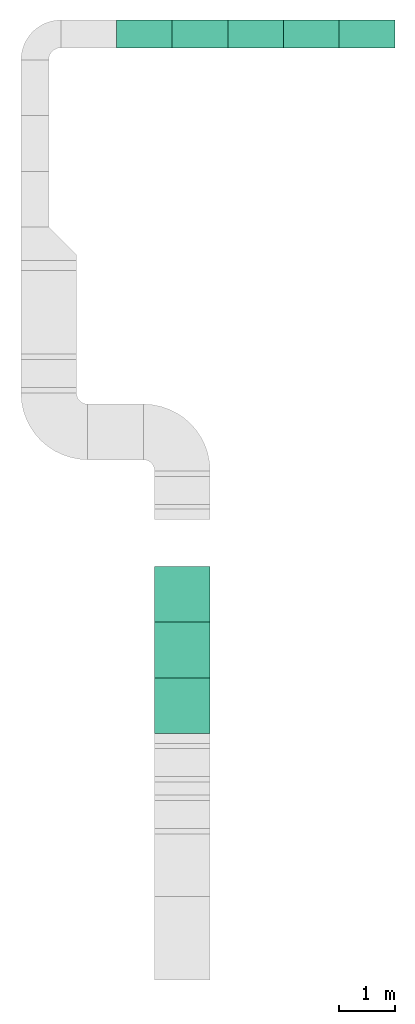
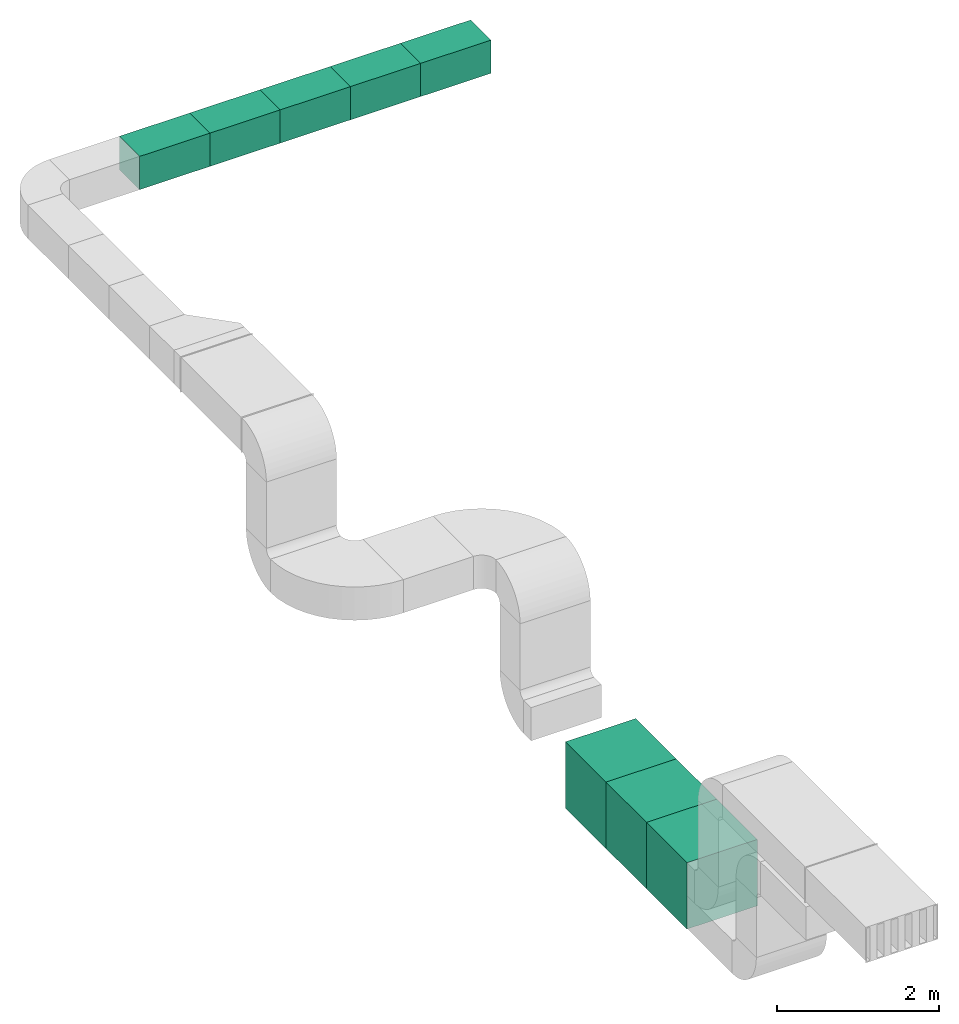
# One storey, part 2 of 3: 5 duct segments, 3 unitary equipment elements.
"""IFC4X3_ADD2 building model written with IfcOpenShell, lengths in millimetres."""

from ifc_helpers import new_model, entity, si_unit, converted_unit, frame, origin_with_axes, origin_2d_with_axis, place, context, subcontext, project, spatial, indexed_curve, outline, extrude, polygons, material, material_profile, profile_set, profile_usage, type_object, element, save


model = new_model("IFC4X3_ADD2")

# Units and contexts
model_context = context("Model", 3, precision=1e-05, world=origin_with_axes())
plan_context = context("Plan", 2, precision=1e-05, world=origin_2d_with_axis())
body_context = subcontext(model_context, "Body", "Model", "MODEL_VIEW")
ifc_project = project(units=[si_unit("VOLUMEUNIT", "CUBIC_METRE"), si_unit("LENGTHUNIT", "METRE", prefix="MILLI"), converted_unit("PLANEANGLEUNIT", "degree", entity("IfcReal", 0.0174532925199433), si_unit("PLANEANGLEUNIT", "RADIAN"), dimensions=[0, 0, 0, 0, 0, 0, 0]), si_unit("AREAUNIT", "SQUARE_METRE")], contexts=[model_context, plan_context])

# Site, building, storey
site_placement = place(None, origin_with_axes())
site = spatial("IfcSite", under=ifc_project, at=site_placement)
building_placement = place(site_placement, origin_with_axes())
building = spatial("IfcBuilding", under=site, at=building_placement, Name="Building")
storey_placement = place(building_placement, origin_with_axes())
storey = spatial("IfcBuildingStorey", under=building, at=storey_placement, Name="Storey")

# Duct segments
ifc_material = material()
ifc_material_profile = material_profile(ifc_material, outline(indexed_curve([(-249.999954223633, 249.999954223633), (249.999954223633, 249.999954223633), (249.999954223633, -249.999954223633), (-249.999954223633, -249.999954223633), (-249.999954223633, 249.999954223633)])))
ifc_profile_set = profile_set([ifc_material_profile])
ifc_profile_usage_1 = profile_usage(ifc_profile_set, cardinal=5)
duct_segment_type = type_object("IfcDuctSegmentType", Name="Duct500x500", PredefinedType="RIGIDSEGMENT", material=ifc_profile_set)
duct_segment_1_placement = place(storey_placement, frame((2084.83171463013, 5958.48846435547, 4035.2087020874), z_axis=(-0.999999999999997, -1.19248735330757e-08, 7.54979012640431e-08), x_axis=(1.1924880638503e-08, -0.999999999999996, 8.74227765734755e-08)))
element("IfcDuctSegment", 1, at=duct_segment_1_placement, inside=storey, type_object=duct_segment_type, material=ifc_profile_usage_1, Name="DuctSegment", context=body_context, shape_type="SweptSolid", body=[
    extrude(outline(indexed_curve([(-249.999954223633, 249.999954223633), (249.999954223633, 249.999954223633), (249.999954223633, -249.999954223633), (-249.999954223633, -249.999954223633), (-249.999954223633, 249.999954223633)])), origin_with_axes(), (0.0, 0.0, 1.0), 1000.00000000001),
])
ifc_profile_usage_2 = profile_usage(ifc_profile_set, cardinal=5)
duct_segment_2_placement = place(storey_placement, frame((3084.83171463013, 5958.48846435547, 4035.2087020874), z_axis=(-0.999999999999997, -1.19248735330757e-08, 7.54979012640431e-08), x_axis=(1.1924880638503e-08, -0.999999999999996, 8.74227765734755e-08)))
element("IfcDuctSegment", 2, at=duct_segment_2_placement, inside=storey, type_object=duct_segment_type, material=ifc_profile_usage_2, Name="DuctSegment", context=body_context, shape_type="SweptSolid", body=[
    extrude(outline(indexed_curve([(-249.999954223633, 249.999954223633), (249.999954223633, 249.999954223633), (249.999954223633, -249.999954223633), (-249.999954223633, -249.999954223633), (-249.999954223633, 249.999954223633)])), origin_with_axes(), (0.0, 0.0, 1.0), 1000.00000000001),
])
ifc_profile_usage_3 = profile_usage(ifc_profile_set, cardinal=5)
duct_segment_3_placement = place(storey_placement, frame((4084.83171463013, 5958.48846435547, 4035.2087020874), z_axis=(-0.999999999999997, -1.19248735330757e-08, 7.54979012640431e-08), x_axis=(1.1924880638503e-08, -0.999999999999996, 8.74227765734755e-08)))
element("IfcDuctSegment", 3, at=duct_segment_3_placement, inside=storey, type_object=duct_segment_type, material=ifc_profile_usage_3, Name="DuctSegment", context=body_context, shape_type="SweptSolid", body=[
    extrude(outline(indexed_curve([(-249.999954223633, 249.999954223633), (249.999954223633, 249.999954223633), (249.999954223633, -249.999954223633), (-249.999954223633, -249.999954223633), (-249.999954223633, 249.999954223633)])), origin_with_axes(), (0.0, 0.0, 1.0), 1000.00000000001),
])
ifc_profile_usage_4 = profile_usage(ifc_profile_set, cardinal=5)
duct_segment_4_placement = place(storey_placement, frame((5084.83171463013, 5958.48846435547, 4035.2087020874), z_axis=(-0.999999999999997, -1.19248735330757e-08, 7.54979012640431e-08), x_axis=(1.1924880638503e-08, -0.999999999999996, 8.74227765734755e-08)))
element("IfcDuctSegment", 4, at=duct_segment_4_placement, inside=storey, type_object=duct_segment_type, material=ifc_profile_usage_4, Name="DuctSegment", context=body_context, shape_type="SweptSolid", body=[
    extrude(outline(indexed_curve([(-249.999954223633, 249.999954223633), (249.999954223633, 249.999954223633), (249.999954223633, -249.999954223633), (-249.999954223633, -249.999954223633), (-249.999954223633, 249.999954223633)])), origin_with_axes(), (0.0, 0.0, 1.0), 1000.00000000001),
])
ifc_profile_usage_5 = profile_usage(ifc_profile_set, cardinal=5)
duct_segment_5_placement = place(storey_placement, frame((6084.83171463013, 5958.48846435547, 4035.2087020874), z_axis=(-0.999999999999997, -1.19248735330757e-08, 7.54979012640431e-08), x_axis=(1.1924880638503e-08, -0.999999999999996, 8.74227765734755e-08)))
element("IfcDuctSegment", 5, at=duct_segment_5_placement, inside=storey, type_object=duct_segment_type, material=ifc_profile_usage_5, Name="DuctSegment", context=body_context, shape_type="SweptSolid", body=[
    extrude(outline(indexed_curve([(-249.999954223633, 249.999954223633), (249.999954223633, 249.999954223633), (249.999954223633, -249.999954223633), (-249.999954223633, -249.999954223633), (-249.999954223633, 249.999954223633)])), origin_with_axes(), (0.0, 0.0, 1.0), 1000.00000000001),
])

# Unitary equipment
for number, where, z_axis, x_axis, name in (
    (6, (2266.84713363647, -6109.40551757812, 386.166274547577), (0.0, 0.0, 1.0), (1.0, 0.0, 0.0), "Cube"),
    (7, (2266.84713363647, -5109.40551757812, 386.166274547577), (0.0, 0.0, 1.0), (1.0, 0.0, 0.0), "Cube"),
    (8, (2266.84713363647, -4109.40551757812, 386.166274547577), (0.0, 0.0, 1.0), (1.0, 0.0, 0.0), "Cube"),
):
    element("IfcUnitaryEquipment", number, at=place(storey_placement, frame(where, z_axis=z_axis, x_axis=x_axis)), inside=storey, Name=name, PredefinedType="AIRHANDLER", context=body_context, shape_type="Tessellation", body=[
        polygons([(-500.0, 499.999970197678, -499.999970197678), (-500.0, -499.999970197678, -499.999970197678), (-500.0, -499.999970197678, 499.999970197678), (499.99988079071, 499.999970197678, -499.999970197678), (-500.0, 499.999970197678, 499.999970197678), (499.99988079071, -499.999970197678, -499.999970197678), (499.99988079071, 499.999970197678, 499.999970197678), (499.99988079071, -499.999970197678, 499.999970197678)], [[[5, 7, 4, 1]], [[7, 8, 6, 4]], [[8, 3, 2, 6]], [[4, 6, 2, 1]], [[5, 3, 8, 7]], [[3, 5, 1, 2]]]),
    ])

save(model, "model.ifc")
